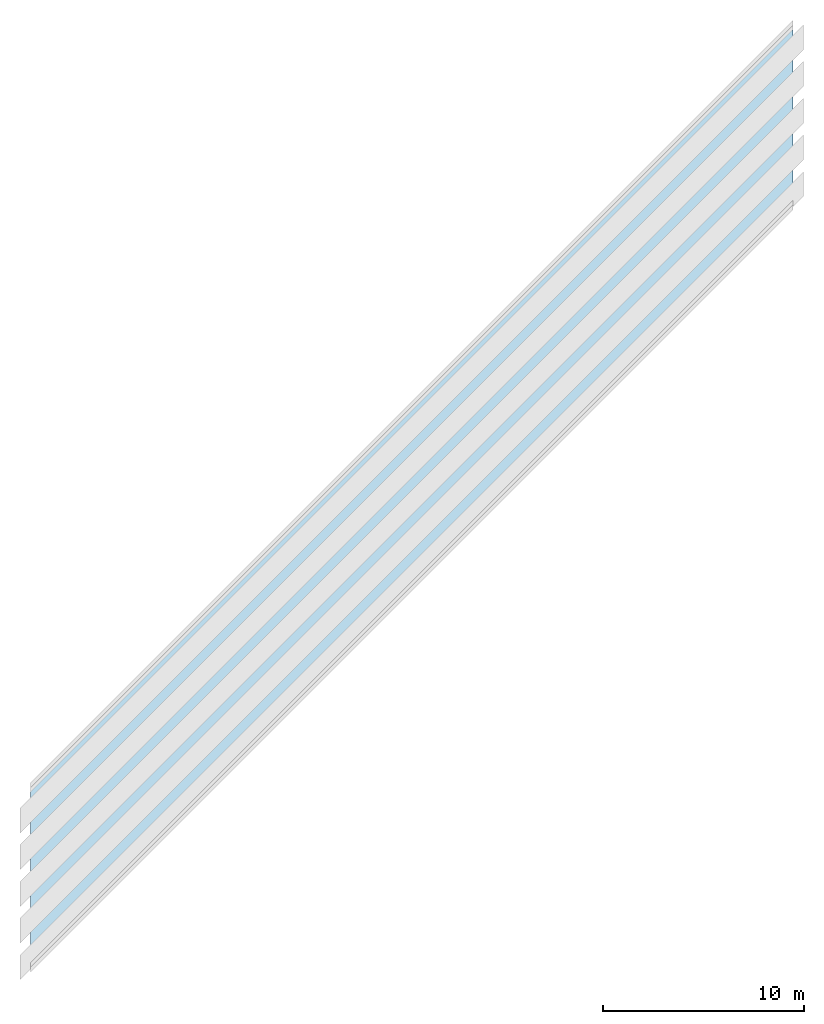
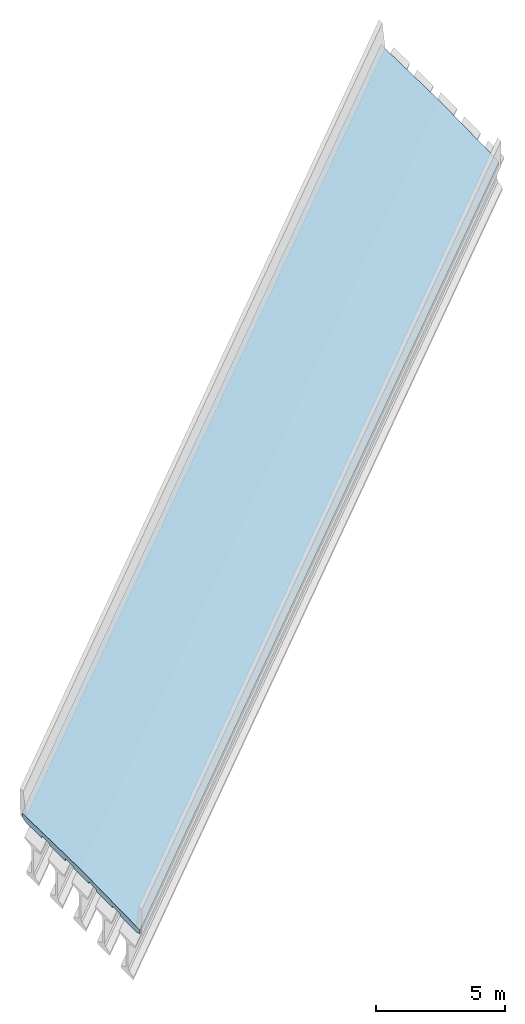
# Not in any storey, part 2 of 3: 1 slab.
"""IFC4X3_ADD2 model written with IfcOpenShell, lengths in metres."""

from ifc_helpers import new_model, entity, si_unit, direction, origin_with_axes, place, context, project, spatial, element, save


model = new_model("IFC4X3_ADD2")

# Units and contexts
model_context = context("Model", 3, precision=1e-05, world=origin_with_axes(), true_north=direction((0.0, 1.0)))
ifc_project = project(units=[si_unit("LENGTHUNIT", "METRE"), si_unit("PLANEANGLEUNIT", "RADIAN")], contexts=[model_context])

# Site, bridge, bridge parts
placement = place(None, origin_with_axes())
site = spatial("IfcSite", under=ifc_project, at=placement, CompositionType="ELEMENT")
bridge = spatial("IfcBridge", under=site, CompositionType="COMPLEX", PredefinedType="GIRDER")
bridge_part_1 = spatial("IfcBridgePart", under=bridge, CompositionType="PARTIAL", PredefinedType="SUPERSTRUCTURE", UsageType="LONGITUDINAL")
bridge_part_2 = spatial("IfcBridgePart", under=bridge_part_1, CompositionType="PARTIAL", PredefinedType="DECK", UsageType="LONGITUDINAL")

# Slab
gradient_curve = entity("IfcGradientCurve", [entity("IfcCurveSegment", "CONTSAMEGRADIENT", entity("IfcAxis2Placement2D", entity("IfcCartesianPoint", [0.0, 0.0]), entity("IfcDirection", [1.0, 0.0])), entity("IfcLengthMeasure", 0.0), entity("IfcLengthMeasure", 139.624), entity("IfcLine", entity("IfcCartesianPoint", [0.0, 0.0]), entity("IfcVector", entity("IfcDirection", [1.0, 0.0]), 1.0))), entity("IfcCurveSegment", "DISCONTINUOUS", entity("IfcAxis2Placement2D", entity("IfcCartesianPoint", [0.0, 0.0]), entity("IfcDirection", [1.0, 0.0])), entity("IfcLengthMeasure", 0.0), entity("IfcLengthMeasure", 0.0), entity("IfcLine", entity("IfcCartesianPoint", [0.0, 0.0]), entity("IfcVector", entity("IfcDirection", [1.0, 0.0]), 1.0)))], False, entity("IfcCompositeCurve", [entity("IfcCurveSegment", "CONTSAMEGRADIENT", entity("IfcAxis2Placement2D", entity("IfcCartesianPoint", [-39.624, 0.0]), entity("IfcDirection", [1.0, 0.0])), entity("IfcLengthMeasure", 0.0), entity("IfcLengthMeasure", 139.624), entity("IfcLine", entity("IfcCartesianPoint", [0.0, 0.0]), entity("IfcVector", entity("IfcDirection", [1.0, 0.0]), 1.0))), entity("IfcCurveSegment", "DISCONTINUOUS", entity("IfcAxis2Placement2D", entity("IfcCartesianPoint", [100.0, 0.0]), entity("IfcDirection", [1.0, 0.0])), entity("IfcLengthMeasure", 0.0), entity("IfcLengthMeasure", 0.0), entity("IfcLine", entity("IfcCartesianPoint", [0.0, 0.0]), entity("IfcVector", entity("IfcDirection", [1.0, 0.0]), 1.0)))], False))
cartesian_point_1 = entity("IfcCartesianPoint", [4.572, -0.26924])
cartesian_point_2 = entity("IfcCartesianPoint", [4.572, -0.26924])
cartesian_point_3 = entity("IfcCartesianPoint", [4.572, -0.26924])
cartesian_point_4 = entity("IfcCartesianPoint", [4.572, -0.26924])
cartesian_point_5 = entity("IfcCartesianPoint", [4.572, -0.26924])
cartesian_point_6 = entity("IfcCartesianPoint", [4.572, -0.26924])
cartesian_point_7 = entity("IfcCartesianPoint", [4.572, -0.26924])
cartesian_point_8 = entity("IfcCartesianPoint", [4.572, -0.26924])
cartesian_point_9 = entity("IfcCartesianPoint", [4.572, -0.26924])
cartesian_point_10 = entity("IfcCartesianPoint", [4.572, -0.26924])
cartesian_point_11 = entity("IfcCartesianPoint", [4.572, -0.26924])
element("IfcSlab", 1, at=placement, inside=bridge_part_2, PredefinedType="FLOOR", context=model_context, shape_type="AdvancedSweptSolid", body=[
    entity("IfcSectionedSolidHorizontal", gradient_curve, [entity("IfcArbitraryClosedProfileDef", "AREA", None, entity("IfcPolyline", [cartesian_point_1, entity("IfcCartesianPoint", [4.572, -0.09144]), entity("IfcCartesianPoint", [0.0, 0.0]), entity("IfcCartesianPoint", [-4.572, -0.09144]), entity("IfcCartesianPoint", [-4.572, -0.26924]), entity("IfcCartesianPoint", [-4.2799, -0.352552]), entity("IfcCartesianPoint", [-3.0353, -0.352552]), entity("IfcCartesianPoint", [-3.0353, -0.270256]), entity("IfcCartesianPoint", [-3.01625, -0.251206]), entity("IfcCartesianPoint", [-2.47015, -0.239522]), entity("IfcCartesianPoint", [-2.4511, -0.258572]), entity("IfcCartesianPoint", [-2.4511, -0.315976]), entity("IfcCartesianPoint", [-1.2065, -0.315976]), entity("IfcCartesianPoint", [-1.2065, -0.23368]), entity("IfcCartesianPoint", [-1.18745, -0.21463]), entity("IfcCartesianPoint", [-0.64135, -0.202946]), entity("IfcCartesianPoint", [-0.6223, -0.221996]), entity("IfcCartesianPoint", [-0.6223, -0.2794]), entity("IfcCartesianPoint", [0.6223, -0.2794]), entity("IfcCartesianPoint", [0.6223, -0.221996]), entity("IfcCartesianPoint", [0.64135, -0.202946]), entity("IfcCartesianPoint", [1.18745, -0.21463]), entity("IfcCartesianPoint", [1.2065, -0.23368]), entity("IfcCartesianPoint", [1.2065, -0.315976]), entity("IfcCartesianPoint", [2.4511, -0.315976]), entity("IfcCartesianPoint", [2.4511, -0.258572]), entity("IfcCartesianPoint", [2.47015, -0.239522]), entity("IfcCartesianPoint", [3.01625, -0.251206]), entity("IfcCartesianPoint", [3.0353, -0.270256]), entity("IfcCartesianPoint", [3.0353, -0.352552]), entity("IfcCartesianPoint", [4.2799, -0.352552]), cartesian_point_1])), entity("IfcArbitraryClosedProfileDef", "AREA", None, entity("IfcPolyline", [cartesian_point_2, entity("IfcCartesianPoint", [4.572, -0.09144]), entity("IfcCartesianPoint", [0.0, 0.0]), entity("IfcCartesianPoint", [-4.572, -0.09144]), entity("IfcCartesianPoint", [-4.572, -0.26924]), entity("IfcCartesianPoint", [-4.2799, -0.327406]), entity("IfcCartesianPoint", [-3.0353, -0.327406]), entity("IfcCartesianPoint", [-3.0353, -0.270256]), entity("IfcCartesianPoint", [-3.01625, -0.251206]), entity("IfcCartesianPoint", [-2.47015, -0.239522]), entity("IfcCartesianPoint", [-2.4511, -0.258572]), entity("IfcCartesianPoint", [-2.4511, -0.29083]), entity("IfcCartesianPoint", [-1.2065, -0.29083]), entity("IfcCartesianPoint", [-1.2065, -0.23368]), entity("IfcCartesianPoint", [-1.18745, -0.21463]), entity("IfcCartesianPoint", [-0.64135, -0.202946]), entity("IfcCartesianPoint", [-0.6223, -0.221996]), entity("IfcCartesianPoint", [-0.6223, -0.254254]), entity("IfcCartesianPoint", [0.6223, -0.254254]), entity("IfcCartesianPoint", [0.6223, -0.221996]), entity("IfcCartesianPoint", [0.64135, -0.202946]), entity("IfcCartesianPoint", [1.18745, -0.21463]), entity("IfcCartesianPoint", [1.2065, -0.23368]), entity("IfcCartesianPoint", [1.2065, -0.29083]), entity("IfcCartesianPoint", [2.4511, -0.29083]), entity("IfcCartesianPoint", [2.4511, -0.258572]), entity("IfcCartesianPoint", [2.47015, -0.239522]), entity("IfcCartesianPoint", [3.01625, -0.251206]), entity("IfcCartesianPoint", [3.0353, -0.270256]), entity("IfcCartesianPoint", [3.0353, -0.327406]), entity("IfcCartesianPoint", [4.2799, -0.327406]), cartesian_point_2])), entity("IfcArbitraryClosedProfileDef", "AREA", None, entity("IfcPolyline", [cartesian_point_3, entity("IfcCartesianPoint", [4.572, -0.09144]), entity("IfcCartesianPoint", [0.0, 0.0]), entity("IfcCartesianPoint", [-4.572, -0.09144]), entity("IfcCartesianPoint", [-4.572, -0.26924]), entity("IfcCartesianPoint", [-4.2799, -0.307848]), entity("IfcCartesianPoint", [-3.0353, -0.307848]), entity("IfcCartesianPoint", [-3.0353, -0.270256]), entity("IfcCartesianPoint", [-3.01625, -0.251206]), entity("IfcCartesianPoint", [-2.47015, -0.239522]), entity("IfcCartesianPoint", [-2.4511, -0.258572]), entity("IfcCartesianPoint", [-2.4511, -0.271272]), entity("IfcCartesianPoint", [-1.2065, -0.271272]), entity("IfcCartesianPoint", [-1.2065, -0.23368]), entity("IfcCartesianPoint", [-1.18745, -0.21463]), entity("IfcCartesianPoint", [-0.64135, -0.202946]), entity("IfcCartesianPoint", [-0.6223, -0.221996]), entity("IfcCartesianPoint", [-0.6223, -0.234696]), entity("IfcCartesianPoint", [0.6223, -0.234696]), entity("IfcCartesianPoint", [0.6223, -0.221996]), entity("IfcCartesianPoint", [0.64135, -0.202946]), entity("IfcCartesianPoint", [1.18745, -0.21463]), entity("IfcCartesianPoint", [1.2065, -0.23368]), entity("IfcCartesianPoint", [1.2065, -0.271272]), entity("IfcCartesianPoint", [2.4511, -0.271272]), entity("IfcCartesianPoint", [2.4511, -0.258572]), entity("IfcCartesianPoint", [2.47015, -0.239522]), entity("IfcCartesianPoint", [3.01625, -0.251206]), entity("IfcCartesianPoint", [3.0353, -0.270256]), entity("IfcCartesianPoint", [3.0353, -0.307848]), entity("IfcCartesianPoint", [4.2799, -0.307848]), cartesian_point_3])), entity("IfcArbitraryClosedProfileDef", "AREA", None, entity("IfcPolyline", [cartesian_point_4, entity("IfcCartesianPoint", [4.572, -0.09144]), entity("IfcCartesianPoint", [0.0, 0.0]), entity("IfcCartesianPoint", [-4.572, -0.09144]), entity("IfcCartesianPoint", [-4.572, -0.26924]), entity("IfcCartesianPoint", [-4.2799, -0.293878]), entity("IfcCartesianPoint", [-3.0353, -0.293878]), entity("IfcCartesianPoint", [-3.0353, -0.270256]), entity("IfcCartesianPoint", [-3.01625, -0.251206]), entity("IfcCartesianPoint", [-2.47015, -0.239522]), entity("IfcCartesianPoint", [-2.4511, -0.258572]), entity("IfcCartesianPoint", [-2.4511, -0.257302]), entity("IfcCartesianPoint", [-1.2065, -0.257302]), entity("IfcCartesianPoint", [-1.2065, -0.23368]), entity("IfcCartesianPoint", [-1.18745, -0.21463]), entity("IfcCartesianPoint", [-0.64135, -0.202946]), entity("IfcCartesianPoint", [-0.6223, -0.221996]), entity("IfcCartesianPoint", [-0.6223, -0.220726]), entity("IfcCartesianPoint", [0.6223, -0.220726]), entity("IfcCartesianPoint", [0.6223, -0.221996]), entity("IfcCartesianPoint", [0.64135, -0.202946]), entity("IfcCartesianPoint", [1.18745, -0.21463]), entity("IfcCartesianPoint", [1.2065, -0.23368]), entity("IfcCartesianPoint", [1.2065, -0.257302]), entity("IfcCartesianPoint", [2.4511, -0.257302]), entity("IfcCartesianPoint", [2.4511, -0.258572]), entity("IfcCartesianPoint", [2.47015, -0.239522]), entity("IfcCartesianPoint", [3.01625, -0.251206]), entity("IfcCartesianPoint", [3.0353, -0.270256]), entity("IfcCartesianPoint", [3.0353, -0.293878]), entity("IfcCartesianPoint", [4.2799, -0.293878]), cartesian_point_4])), entity("IfcArbitraryClosedProfileDef", "AREA", None, entity("IfcPolyline", [cartesian_point_5, entity("IfcCartesianPoint", [4.572, -0.09144]), entity("IfcCartesianPoint", [0.0, 0.0]), entity("IfcCartesianPoint", [-4.572, -0.09144]), entity("IfcCartesianPoint", [-4.572, -0.26924]), entity("IfcCartesianPoint", [-4.2799, -0.285496]), entity("IfcCartesianPoint", [-3.0353, -0.285496]), entity("IfcCartesianPoint", [-3.0353, -0.270256]), entity("IfcCartesianPoint", [-3.01625, -0.251206]), entity("IfcCartesianPoint", [-2.47015, -0.239522]), entity("IfcCartesianPoint", [-2.4511, -0.258572]), entity("IfcCartesianPoint", [-2.4511, -0.24892]), entity("IfcCartesianPoint", [-1.2065, -0.24892]), entity("IfcCartesianPoint", [-1.2065, -0.23368]), entity("IfcCartesianPoint", [-1.18745, -0.21463]), entity("IfcCartesianPoint", [-0.64135, -0.202946]), entity("IfcCartesianPoint", [-0.6223, -0.221996]), entity("IfcCartesianPoint", [-0.6223, -0.212344]), entity("IfcCartesianPoint", [0.6223, -0.212344]), entity("IfcCartesianPoint", [0.6223, -0.221996]), entity("IfcCartesianPoint", [0.64135, -0.202946]), entity("IfcCartesianPoint", [1.18745, -0.21463]), entity("IfcCartesianPoint", [1.2065, -0.23368]), entity("IfcCartesianPoint", [1.2065, -0.24892]), entity("IfcCartesianPoint", [2.4511, -0.24892]), entity("IfcCartesianPoint", [2.4511, -0.258572]), entity("IfcCartesianPoint", [2.47015, -0.239522]), entity("IfcCartesianPoint", [3.01625, -0.251206]), entity("IfcCartesianPoint", [3.0353, -0.270256]), entity("IfcCartesianPoint", [3.0353, -0.285496]), entity("IfcCartesianPoint", [4.2799, -0.285496]), cartesian_point_5])), entity("IfcArbitraryClosedProfileDef", "AREA", None, entity("IfcPolyline", [cartesian_point_6, entity("IfcCartesianPoint", [4.572, -0.09144]), entity("IfcCartesianPoint", [0.0, 0.0]), entity("IfcCartesianPoint", [-4.572, -0.09144]), entity("IfcCartesianPoint", [-4.572, -0.26924]), entity("IfcCartesianPoint", [-4.2799, -0.282702]), entity("IfcCartesianPoint", [-3.0353, -0.282702]), entity("IfcCartesianPoint", [-3.0353, -0.270256]), entity("IfcCartesianPoint", [-3.01625, -0.251206]), entity("IfcCartesianPoint", [-2.47015, -0.239522]), entity("IfcCartesianPoint", [-2.4511, -0.258572]), entity("IfcCartesianPoint", [-2.4511, -0.246126]), entity("IfcCartesianPoint", [-1.2065, -0.246126]), entity("IfcCartesianPoint", [-1.2065, -0.23368]), entity("IfcCartesianPoint", [-1.18745, -0.21463]), entity("IfcCartesianPoint", [-0.64135, -0.202946]), entity("IfcCartesianPoint", [-0.6223, -0.221996]), entity("IfcCartesianPoint", [-0.6223, -0.20955]), entity("IfcCartesianPoint", [0.6223, -0.20955]), entity("IfcCartesianPoint", [0.6223, -0.221996]), entity("IfcCartesianPoint", [0.64135, -0.202946]), entity("IfcCartesianPoint", [1.18745, -0.21463]), entity("IfcCartesianPoint", [1.2065, -0.23368]), entity("IfcCartesianPoint", [1.2065, -0.246126]), entity("IfcCartesianPoint", [2.4511, -0.246126]), entity("IfcCartesianPoint", [2.4511, -0.258572]), entity("IfcCartesianPoint", [2.47015, -0.239522]), entity("IfcCartesianPoint", [3.01625, -0.251206]), entity("IfcCartesianPoint", [3.0353, -0.270256]), entity("IfcCartesianPoint", [3.0353, -0.282702]), entity("IfcCartesianPoint", [4.2799, -0.282702]), cartesian_point_6])), entity("IfcArbitraryClosedProfileDef", "AREA", None, entity("IfcPolyline", [cartesian_point_7, entity("IfcCartesianPoint", [4.572, -0.09144]), entity("IfcCartesianPoint", [0.0, 0.0]), entity("IfcCartesianPoint", [-4.572, -0.09144]), entity("IfcCartesianPoint", [-4.572, -0.26924]), entity("IfcCartesianPoint", [-4.2799, -0.285496]), entity("IfcCartesianPoint", [-3.0353, -0.285496]), entity("IfcCartesianPoint", [-3.0353, -0.270256]), entity("IfcCartesianPoint", [-3.01625, -0.251206]), entity("IfcCartesianPoint", [-2.47015, -0.239522]), entity("IfcCartesianPoint", [-2.4511, -0.258572]), entity("IfcCartesianPoint", [-2.4511, -0.24892]), entity("IfcCartesianPoint", [-1.2065, -0.24892]), entity("IfcCartesianPoint", [-1.2065, -0.23368]), entity("IfcCartesianPoint", [-1.18745, -0.21463]), entity("IfcCartesianPoint", [-0.64135, -0.202946]), entity("IfcCartesianPoint", [-0.6223, -0.221996]), entity("IfcCartesianPoint", [-0.6223, -0.212344]), entity("IfcCartesianPoint", [0.6223, -0.212344]), entity("IfcCartesianPoint", [0.6223, -0.221996]), entity("IfcCartesianPoint", [0.64135, -0.202946]), entity("IfcCartesianPoint", [1.18745, -0.21463]), entity("IfcCartesianPoint", [1.2065, -0.23368]), entity("IfcCartesianPoint", [1.2065, -0.24892]), entity("IfcCartesianPoint", [2.4511, -0.24892]), entity("IfcCartesianPoint", [2.4511, -0.258572]), entity("IfcCartesianPoint", [2.47015, -0.239522]), entity("IfcCartesianPoint", [3.01625, -0.251206]), entity("IfcCartesianPoint", [3.0353, -0.270256]), entity("IfcCartesianPoint", [3.0353, -0.285496]), entity("IfcCartesianPoint", [4.2799, -0.285496]), cartesian_point_7])), entity("IfcArbitraryClosedProfileDef", "AREA", None, entity("IfcPolyline", [cartesian_point_8, entity("IfcCartesianPoint", [4.572, -0.09144]), entity("IfcCartesianPoint", [0.0, 0.0]), entity("IfcCartesianPoint", [-4.572, -0.09144]), entity("IfcCartesianPoint", [-4.572, -0.26924]), entity("IfcCartesianPoint", [-4.2799, -0.293878]), entity("IfcCartesianPoint", [-3.0353, -0.293878]), entity("IfcCartesianPoint", [-3.0353, -0.270256]), entity("IfcCartesianPoint", [-3.01625, -0.251206]), entity("IfcCartesianPoint", [-2.47015, -0.239522]), entity("IfcCartesianPoint", [-2.4511, -0.258572]), entity("IfcCartesianPoint", [-2.4511, -0.257302]), entity("IfcCartesianPoint", [-1.2065, -0.257302]), entity("IfcCartesianPoint", [-1.2065, -0.23368]), entity("IfcCartesianPoint", [-1.18745, -0.21463]), entity("IfcCartesianPoint", [-0.64135, -0.202946]), entity("IfcCartesianPoint", [-0.6223, -0.221996]), entity("IfcCartesianPoint", [-0.6223, -0.220726]), entity("IfcCartesianPoint", [0.6223, -0.220726]), entity("IfcCartesianPoint", [0.6223, -0.221996]), entity("IfcCartesianPoint", [0.64135, -0.202946]), entity("IfcCartesianPoint", [1.18745, -0.21463]), entity("IfcCartesianPoint", [1.2065, -0.23368]), entity("IfcCartesianPoint", [1.2065, -0.257302]), entity("IfcCartesianPoint", [2.4511, -0.257302]), entity("IfcCartesianPoint", [2.4511, -0.258572]), entity("IfcCartesianPoint", [2.47015, -0.239522]), entity("IfcCartesianPoint", [3.01625, -0.251206]), entity("IfcCartesianPoint", [3.0353, -0.270256]), entity("IfcCartesianPoint", [3.0353, -0.293878]), entity("IfcCartesianPoint", [4.2799, -0.293878]), cartesian_point_8])), entity("IfcArbitraryClosedProfileDef", "AREA", None, entity("IfcPolyline", [cartesian_point_9, entity("IfcCartesianPoint", [4.572, -0.09144]), entity("IfcCartesianPoint", [0.0, 0.0]), entity("IfcCartesianPoint", [-4.572, -0.09144]), entity("IfcCartesianPoint", [-4.572, -0.26924]), entity("IfcCartesianPoint", [-4.2799, -0.307848]), entity("IfcCartesianPoint", [-3.0353, -0.307848]), entity("IfcCartesianPoint", [-3.0353, -0.270256]), entity("IfcCartesianPoint", [-3.01625, -0.251206]), entity("IfcCartesianPoint", [-2.47015, -0.239522]), entity("IfcCartesianPoint", [-2.4511, -0.258572]), entity("IfcCartesianPoint", [-2.4511, -0.271272]), entity("IfcCartesianPoint", [-1.2065, -0.271272]), entity("IfcCartesianPoint", [-1.2065, -0.23368]), entity("IfcCartesianPoint", [-1.18745, -0.21463]), entity("IfcCartesianPoint", [-0.64135, -0.202946]), entity("IfcCartesianPoint", [-0.6223, -0.221996]), entity("IfcCartesianPoint", [-0.6223, -0.234696]), entity("IfcCartesianPoint", [0.6223, -0.234696]), entity("IfcCartesianPoint", [0.6223, -0.221996]), entity("IfcCartesianPoint", [0.64135, -0.202946]), entity("IfcCartesianPoint", [1.18745, -0.21463]), entity("IfcCartesianPoint", [1.2065, -0.23368]), entity("IfcCartesianPoint", [1.2065, -0.271272]), entity("IfcCartesianPoint", [2.4511, -0.271272]), entity("IfcCartesianPoint", [2.4511, -0.258572]), entity("IfcCartesianPoint", [2.47015, -0.239522]), entity("IfcCartesianPoint", [3.01625, -0.251206]), entity("IfcCartesianPoint", [3.0353, -0.270256]), entity("IfcCartesianPoint", [3.0353, -0.307848]), entity("IfcCartesianPoint", [4.2799, -0.307848]), cartesian_point_9])), entity("IfcArbitraryClosedProfileDef", "AREA", None, entity("IfcPolyline", [cartesian_point_10, entity("IfcCartesianPoint", [4.572, -0.09144]), entity("IfcCartesianPoint", [0.0, 0.0]), entity("IfcCartesianPoint", [-4.572, -0.09144]), entity("IfcCartesianPoint", [-4.572, -0.26924]), entity("IfcCartesianPoint", [-4.2799, -0.327406]), entity("IfcCartesianPoint", [-3.0353, -0.327406]), entity("IfcCartesianPoint", [-3.0353, -0.270256]), entity("IfcCartesianPoint", [-3.01625, -0.251206]), entity("IfcCartesianPoint", [-2.47015, -0.239522]), entity("IfcCartesianPoint", [-2.4511, -0.258572]), entity("IfcCartesianPoint", [-2.4511, -0.29083]), entity("IfcCartesianPoint", [-1.2065, -0.29083]), entity("IfcCartesianPoint", [-1.2065, -0.23368]), entity("IfcCartesianPoint", [-1.18745, -0.21463]), entity("IfcCartesianPoint", [-0.64135, -0.202946]), entity("IfcCartesianPoint", [-0.6223, -0.221996]), entity("IfcCartesianPoint", [-0.6223, -0.254254]), entity("IfcCartesianPoint", [0.6223, -0.254254]), entity("IfcCartesianPoint", [0.6223, -0.221996]), entity("IfcCartesianPoint", [0.64135, -0.202946]), entity("IfcCartesianPoint", [1.18745, -0.21463]), entity("IfcCartesianPoint", [1.2065, -0.23368]), entity("IfcCartesianPoint", [1.2065, -0.29083]), entity("IfcCartesianPoint", [2.4511, -0.29083]), entity("IfcCartesianPoint", [2.4511, -0.258572]), entity("IfcCartesianPoint", [2.47015, -0.239522]), entity("IfcCartesianPoint", [3.01625, -0.251206]), entity("IfcCartesianPoint", [3.0353, -0.270256]), entity("IfcCartesianPoint", [3.0353, -0.327406]), entity("IfcCartesianPoint", [4.2799, -0.327406]), cartesian_point_10])), entity("IfcArbitraryClosedProfileDef", "AREA", None, entity("IfcPolyline", [cartesian_point_11, entity("IfcCartesianPoint", [4.572, -0.09144]), entity("IfcCartesianPoint", [0.0, 0.0]), entity("IfcCartesianPoint", [-4.572, -0.09144]), entity("IfcCartesianPoint", [-4.572, -0.26924]), entity("IfcCartesianPoint", [-4.2799, -0.352552]), entity("IfcCartesianPoint", [-3.0353, -0.352552]), entity("IfcCartesianPoint", [-3.0353, -0.270256]), entity("IfcCartesianPoint", [-3.01625, -0.251206]), entity("IfcCartesianPoint", [-2.47015, -0.239522]), entity("IfcCartesianPoint", [-2.4511, -0.258572]), entity("IfcCartesianPoint", [-2.4511, -0.315976]), entity("IfcCartesianPoint", [-1.2065, -0.315976]), entity("IfcCartesianPoint", [-1.2065, -0.23368]), entity("IfcCartesianPoint", [-1.18745, -0.21463]), entity("IfcCartesianPoint", [-0.64135, -0.202946]), entity("IfcCartesianPoint", [-0.6223, -0.221996]), entity("IfcCartesianPoint", [-0.6223, -0.2794]), entity("IfcCartesianPoint", [0.6223, -0.2794]), entity("IfcCartesianPoint", [0.6223, -0.221996]), entity("IfcCartesianPoint", [0.64135, -0.202946]), entity("IfcCartesianPoint", [1.18745, -0.21463]), entity("IfcCartesianPoint", [1.2065, -0.23368]), entity("IfcCartesianPoint", [1.2065, -0.315976]), entity("IfcCartesianPoint", [2.4511, -0.315976]), entity("IfcCartesianPoint", [2.4511, -0.258572]), entity("IfcCartesianPoint", [2.47015, -0.239522]), entity("IfcCartesianPoint", [3.01625, -0.251206]), entity("IfcCartesianPoint", [3.0353, -0.270256]), entity("IfcCartesianPoint", [3.0353, -0.352552]), entity("IfcCartesianPoint", [4.2799, -0.352552]), cartesian_point_11]))], [entity("IfcAxis2PlacementLinear", entity("IfcPointByDistanceExpression", entity("IfcLengthMeasure", 40.4495), None, None, None, gradient_curve)), entity("IfcAxis2PlacementLinear", entity("IfcPointByDistanceExpression", entity("IfcLengthMeasure", 44.2468), None, None, None, gradient_curve)), entity("IfcAxis2PlacementLinear", entity("IfcPointByDistanceExpression", entity("IfcLengthMeasure", 48.0441), None, None, None, gradient_curve)), entity("IfcAxis2PlacementLinear", entity("IfcPointByDistanceExpression", entity("IfcLengthMeasure", 51.8414), None, None, None, gradient_curve)), entity("IfcAxis2PlacementLinear", entity("IfcPointByDistanceExpression", entity("IfcLengthMeasure", 55.6387), None, None, None, gradient_curve)), entity("IfcAxis2PlacementLinear", entity("IfcPointByDistanceExpression", entity("IfcLengthMeasure", 59.436), None, None, None, gradient_curve)), entity("IfcAxis2PlacementLinear", entity("IfcPointByDistanceExpression", entity("IfcLengthMeasure", 63.2333), None, None, None, gradient_curve)), entity("IfcAxis2PlacementLinear", entity("IfcPointByDistanceExpression", entity("IfcLengthMeasure", 67.0306), None, None, None, gradient_curve)), entity("IfcAxis2PlacementLinear", entity("IfcPointByDistanceExpression", entity("IfcLengthMeasure", 70.8279), None, None, None, gradient_curve)), entity("IfcAxis2PlacementLinear", entity("IfcPointByDistanceExpression", entity("IfcLengthMeasure", 74.6252), None, None, None, gradient_curve)), entity("IfcAxis2PlacementLinear", entity("IfcPointByDistanceExpression", entity("IfcLengthMeasure", 78.4225), None, None, None, gradient_curve))]),
])

save(model, "model.ifc")
